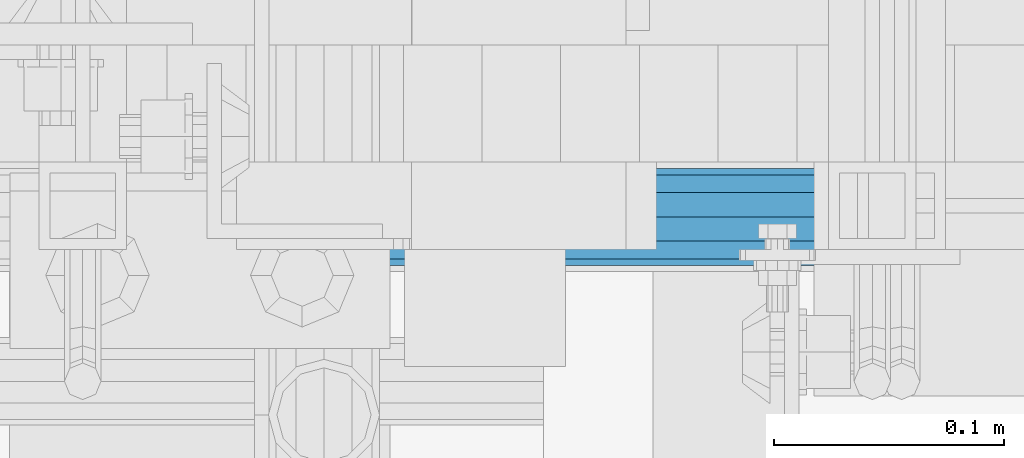
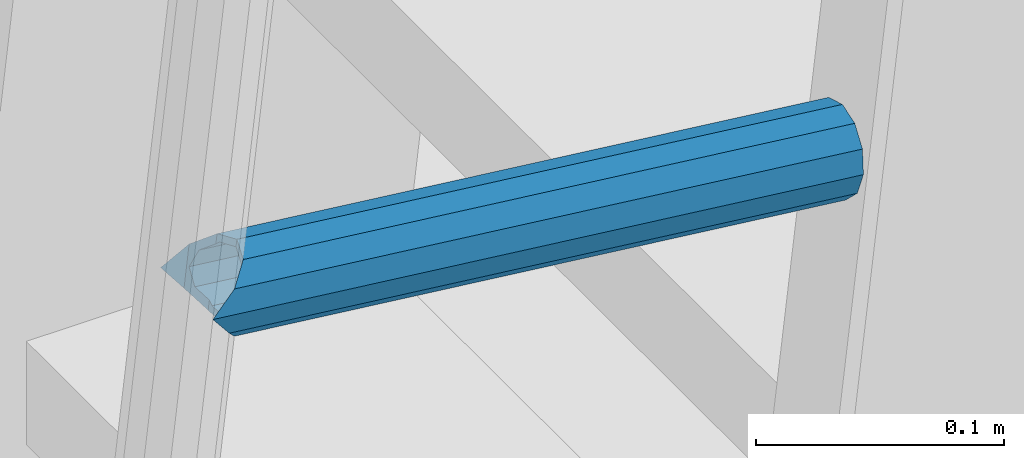
# One storey, part 1138 of 1876: 1 beam, 1 element without a shape of its own.
"""IFC2X3 building model written with IfcOpenShell, lengths in millimetres."""

from ifc_helpers import new_model, si_unit, frame, origin_with_axes, place, context, subcontext, project, spatial, faceted_brep, material, type_object, element, aggregate, save


model = new_model("IFC2X3")

# Units and contexts
model_context = context("Model", 3, precision=1e-05, world=origin_with_axes())
body_context = subcontext(model_context, "Body", "Model", "MODEL_VIEW")
ifc_project = project(units=[si_unit("LENGTHUNIT", "METRE", prefix="MILLI"), si_unit("AREAUNIT", "SQUARE_METRE"), si_unit("VOLUMEUNIT", "CUBIC_METRE"), si_unit("MASSUNIT", "GRAM", prefix="KILO"), si_unit("TIMEUNIT", "SECOND"), si_unit("PLANEANGLEUNIT", "RADIAN"), si_unit("SOLIDANGLEUNIT", "STERADIAN"), si_unit("THERMODYNAMICTEMPERATUREUNIT", "DEGREE_CELSIUS"), si_unit("LUMINOUSINTENSITYUNIT", "LUMEN")], contexts=[model_context])

# Site, building, storey
site_placement = place(None, origin_with_axes())
site = spatial("IfcSite", under=ifc_project, at=site_placement, CompositionType="ELEMENT")
building_placement = place(site_placement, origin_with_axes())
building = spatial("IfcBuilding", under=site, at=building_placement, Name="Undefined", CompositionType="ELEMENT")
storey_placement = place(building_placement, origin_with_axes())
storey = spatial("IfcBuildingStorey", under=building, at=storey_placement, Name="Undefined", CompositionType="ELEMENT", Elevation=0.0)

# Assembly, beam
assembly_placement = place(storey_placement, origin_with_axes())
assembly = element("IfcElementAssembly", 1, at=assembly_placement, inside=storey, Name="RIGHT STRINGER", AssemblyPlace="NOTDEFINED", PredefinedType="RIGID_FRAME")
ifc_material = material()
beam_type = type_object("IfcBeamType", Name="PIPE1-1/4SCH40", PredefinedType="NOTDEFINED")
beam_placement = place(assembly_placement, frame((1710.20914398652, -5954.7125, 21456.6100413654), z_axis=(0.0, 1.0, 0.0), x_axis=(0.993502247476981, 0.0, -0.113812496054638)))
beam = element("IfcBeam", 2, at=beam_placement, type_object=beam_type, material=ifc_material, Name="POST", ObjectType="PIPE1-1/4SCH40", context=body_context, shape_type="Brep", body=[
    faceted_brep([(0.0, 0.0, 21.0820000000003), (10.5410047402225, 10.5410000000047, 18.2575475625836), (10.5410000000002, -10.5410000000002, 18.2575475625836), (10.5410000000002, -10.5410000000002, -18.2575475625836), (10.5410047402225, 10.5410000000047, -18.2575475625836), (-4.28826751885936e-09, 0.0, -21.0820000000003), (18.2575475625836, -18.2575475625836, -10.5409999999993), (18.2575523716411, -13.3999612267653, -10.5410000000002), (13.6205911385651, -8.76300000002811, -15.1779612267264), (11.2725523401174, -1.09139364212751e-11, -17.5259999999998), (13.6205910882173, 8.76299999999537, -15.1779612267264), (18.2575522945893, 13.3999612267216, -10.5410000000002), (18.2575522806238, 18.2575475625817, -10.5410000000002), (21.0819999957121, 17.5259999907203, 0.0), (21.081999995713, 21.0819999907208, 0.0), (18.7339659606611, 15.1779612267237, -8.76299999999992), (18.7339659606627, 15.1779612267237, 8.76299999999992), (18.2575522945893, 13.3999612267216, 10.5410000000002), (18.2575522806238, 18.2575475625817, 10.5410000000002), (13.6205910882217, 8.76299999999537, 15.1779612267264), (11.2725523401217, -1.09139364212751e-11, 17.5259999999998), (13.6205911385692, -8.76300000002811, 15.1779612267264), (18.2575523716411, -13.3999612267653, 10.5410000000002), (18.2575475625836, -18.2575475625836, 10.5409999999993), (18.7339660478675, -15.177961226771, 8.76299999999992), (21.0819999957121, -17.5260000092794, 0.0), (21.0819999957121, -21.0820000092799, 0.0), (18.7339660478659, -15.177961226771, -8.76299999999992), (304.800009609033, -10.5410000004813, -18.2575475625836), (304.800009609034, -18.2575475630765, -10.5410000000002), (304.800009609031, -4.69299266114831e-10, -21.0820000000003), (304.800009609029, 10.5409999995427, -18.2575475625836), (304.800009609028, 18.2575475621416, -10.5410000000002), (304.800009609028, 21.0819999995583, 0.0), (304.800009609028, 18.2575475621416, 10.5410000000002), (304.800009609029, 10.5409999995427, 18.2575475625836), (304.800009609031, -4.69299266114831e-10, 21.0820000000003), (304.800009609033, -10.5410000004813, 18.2575475625836), (304.800009609034, -18.2575475630765, 10.5410000000002), (304.800009609035, -21.0820000004969, 0.0), (304.800009609033, -8.76300000047922, 15.1779612267264), (304.800009609031, -4.69299266114831e-10, 17.5259999999998), (304.800009609029, 8.76299999954426, 15.1779612267264), (304.800009609029, 15.1779612262762, 8.76299999999992), (304.800009609028, 17.5259999995542, 0.0), (304.800009609029, 15.1779612262762, -8.76299999999992), (304.800009609029, 8.76299999954426, -15.1779612267264), (304.800009609031, -4.69299266114831e-10, -17.5259999999998), (304.800009609033, -8.76300000047922, -15.1779612267264), (304.800009609034, -15.1779612272148, -8.76299999999992), (304.800009609034, -17.5260000004928, 0.0), (304.800009609034, -15.1779612272148, 8.76299999999992)], [[[0, 1, 2]], [[3, 4, 5]], [[6, 7, 8, 9, 10, 11, 12, 4, 3]], [[13, 14, 12, 11, 15]], [[16, 17, 18, 14, 13]], [[2, 1, 18, 17, 19, 20, 21, 22, 23]], [[23, 22, 24, 25, 26]], [[26, 25, 27, 7, 6]], [[28, 29, 6, 3]], [[30, 28, 3, 5]], [[31, 30, 5, 4]], [[32, 31, 4, 12]], [[33, 32, 12, 14]], [[34, 33, 14, 18]], [[35, 34, 18, 1]], [[36, 35, 1, 0]], [[37, 36, 0, 2]], [[38, 37, 2, 23]], [[39, 38, 23, 26]], [[29, 39, 26, 6]], [[28, 30, 31, 32, 33, 34, 35, 36, 37, 38, 39, 29], [40, 41, 42, 43, 44, 45, 46, 47, 48, 49, 50, 51]], [[51, 50, 25, 24]], [[21, 40, 51, 24, 22]], [[41, 40, 21, 20]], [[42, 41, 20, 19]], [[43, 42, 19, 17, 16]], [[44, 43, 16, 13]], [[45, 44, 13, 15]], [[10, 46, 45, 15, 11]], [[47, 46, 10, 9]], [[48, 47, 9, 8]], [[49, 48, 8, 7, 27]], [[50, 49, 27, 25]]]),
])
aggregate(assembly, [beam])

save(model, "model.ifc")
